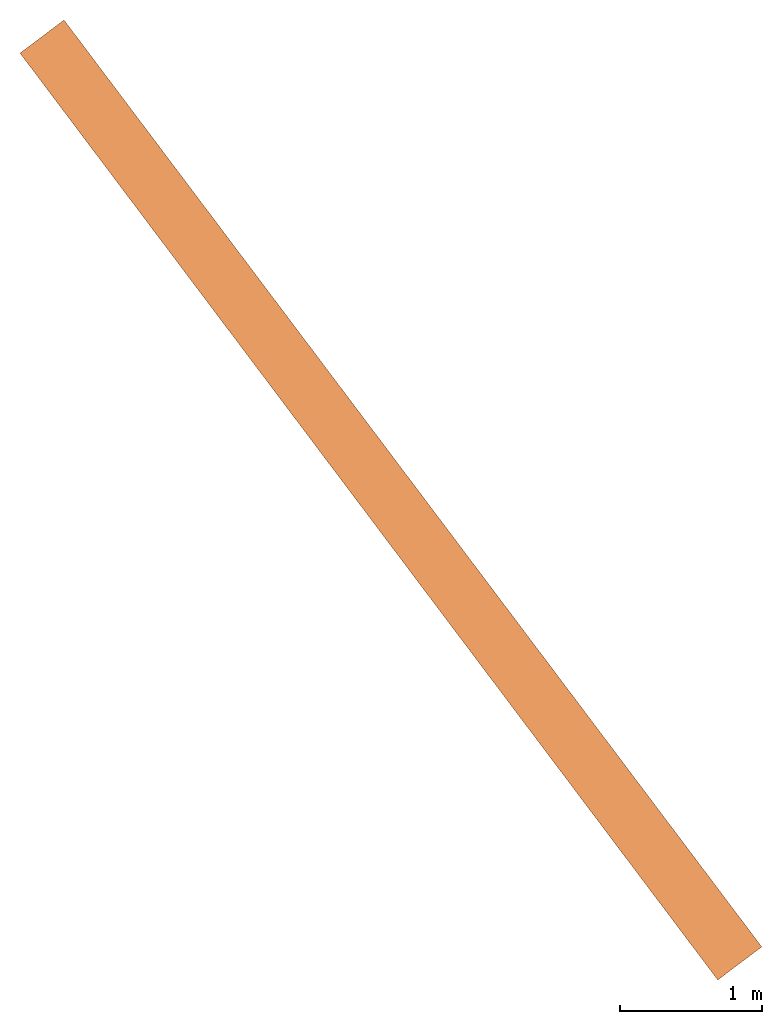
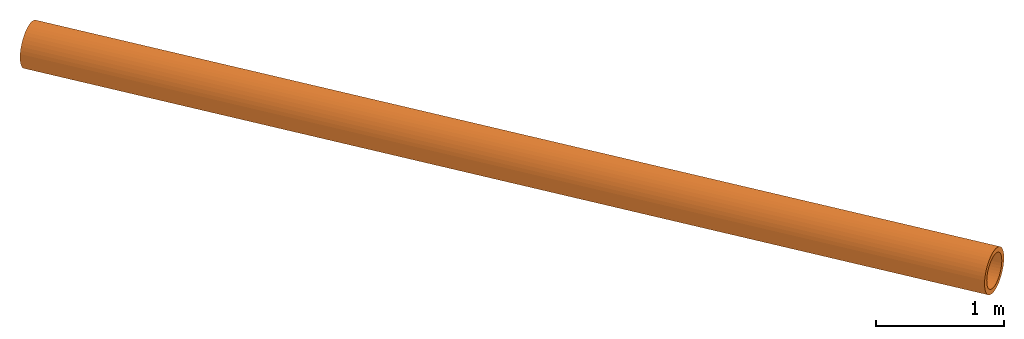
"""IFC2X3 building model written with IfcOpenShell, lengths in metres."""

import ifcopenshell
import ifcopenshell.guid

model = None  # the IFC model being written
_history = None  # IfcOwnerHistory: only IFC2X3 demands one
_inside = {}  # id of a spatial element -> (the spatial element, [elements in it])
_under = {}  # id of a project, library or spatial element -> (it, [spatial elements below it])
_declared = {}  # id of a project -> (the project, [libraries it declares])
_typed = {}  # id of a type object -> (the type object, [elements of that type])
_made_of = {}  # id of a material, layer set ... -> (it, [elements and type objects made of it])


def new_model(schema):
    """Start an empty IFC model of exactly this schema.

    Asked for "IFC4X3", IfcOpenShell would pick the latest addendum, in which some entities
    have other attributes; the version numbers below select the first issue.
    IFC2X3 requires an IfcOwnerHistory on every rooted entity: one is made here for all.
    """
    global model, _history
    if schema == "IFC4X3":
        model = ifcopenshell.file(schema_version=(4, 3, 0, 0))
    else:
        model = ifcopenshell.file(schema=schema)
    _inside.clear()
    _under.clear()
    _declared.clear()
    _typed.clear()
    _made_of.clear()
    _history = None
    if model.schema == "IFC2X3":
        org = make("IfcOrganization", Name="unknown")
        user = make(
            "IfcPersonAndOrganization",
            ThePerson=make("IfcPerson", FamilyName="unknown"),
            TheOrganization=org,
        )
        app = make(
            "IfcApplication",
            ApplicationDeveloper=org,
            Version="unknown",
            ApplicationFullName="unknown",
            ApplicationIdentifier="unknown",
        )
        _history = make(
            "IfcOwnerHistory",
            OwningUser=user,
            OwningApplication=app,
            ChangeAction="ADDED",
            CreationDate=0,
        )
    return model


def make(cls, **values):
    """One entity of the class cls with the attributes given. An attribute that is None is left unset."""
    return model.create_entity(
        cls, **{name: value for name, value in values.items() if value is not None}
    )


def entity(cls, *values):
    """Any entity or typed value of the class cls, its attributes in the order of the schema. None: left unset."""
    e = model.create_entity(cls)
    for i, value in enumerate(values):
        if value is not None:
            e[i] = value
    return e


def rooted(cls, **values):
    """An entity with a GlobalId (a new one), such as an element, a storey or a relation."""
    return make(cls, GlobalId=ifcopenshell.guid.new(), OwnerHistory=_history, **values)


def si_unit(unit_type, name, prefix=None):
    """IfcSIUnit, for example si_unit("LENGTHUNIT", "METRE", prefix="MILLI")."""
    return make("IfcSIUnit", UnitType=unit_type, Prefix=prefix, Name=name)


def converted_unit(unit_type, name, factor, base, dimensions=None, offset=None):
    """IfcConversionBasedUnit, such as the inch: factor (a typed value) times the base unit."""
    return make(
        "IfcConversionBasedUnit"
        if offset is None
        else "IfcConversionBasedUnitWithOffset",
        ConversionOffset=offset,
        Dimensions=None
        if dimensions is None
        else entity("IfcDimensionalExponents", *dimensions),
        UnitType=unit_type,
        Name=name,
        ConversionFactor=make(
            "IfcMeasureWithUnit", ValueComponent=factor, UnitComponent=base
        ),
    )


def assignment(units):
    """IfcUnitAssignment: the units of a project."""
    return None if units is None else make("IfcUnitAssignment", Units=units)


def point(xyz):
    """IfcCartesianPoint."""
    return None if xyz is None else make("IfcCartesianPoint", Coordinates=xyz)


def direction(xyz):
    """IfcDirection."""
    return None if xyz is None else make("IfcDirection", DirectionRatios=xyz)


def frame(location, z_axis=None, x_axis=None):
    """IfcAxis2Placement3D, a coordinate frame: its origin and axes. An axis left out is left unset."""
    return make(
        "IfcAxis2Placement3D",
        Location=point(location),
        Axis=direction(z_axis),
        RefDirection=direction(x_axis),
    )


def origin_with_axes():
    """The frame at (0, 0, 0) with the z axis (0, 0, 1) and the x axis (1, 0, 0) written out."""
    return frame((0.0, 0.0, 0.0), z_axis=(0.0, 0.0, 1.0), x_axis=(1.0, 0.0, 0.0))


def place(relative_to, where):
    """IfcLocalPlacement: puts the frame where relative to a parent placement (None: the world)."""
    return make(
        "IfcLocalPlacement", PlacementRelTo=relative_to, RelativePlacement=where
    )


def context(
    kind, dimensions, precision=None, world=None, true_north=None, identifier=None
):
    """IfcGeometricRepresentationContext, for example the 3D "Model" context."""
    return make(
        "IfcGeometricRepresentationContext",
        ContextIdentifier=identifier,
        ContextType=kind,
        CoordinateSpaceDimension=dimensions,
        Precision=precision,
        WorldCoordinateSystem=world,
        TrueNorth=true_north,
    )


def project(units=None, contexts=None):
    """IfcProject with its units and contexts."""
    return rooted(
        "IfcProject",
        Name="project",
        RepresentationContexts=contexts,
        UnitsInContext=assignment(units),
    )


def spatial(cls, under=None, at=None, **own):
    """A site, building, storey or space (cls), placed at a placement, below another one or the project."""
    s = rooted(cls, ObjectPlacement=at, **own)
    if under is not None:
        _under.setdefault(under.id(), (under, []))[1].append(s)
    return s


def faces_of(points, faces, orient=None, outer=None):
    """IfcFace entities. A face is a list of loops; a loop is a list of indices into points, from 0.

    orient and outer hold one flag for each loop. By default every Orientation is true, the
    first loop of a face is its IfcFaceOuterBound and the others are IfcFaceBound.
    """
    made = []
    for i, loops in enumerate(faces):
        bounds = []
        for j, loop in enumerate(loops):
            is_outer = j == 0 if outer is None else outer[i][j]
            bounds.append(
                make(
                    "IfcFaceOuterBound" if is_outer else "IfcFaceBound",
                    Bound=make("IfcPolyLoop", Polygon=[points[k] for k in loop]),
                    Orientation=True if orient is None else orient[i][j],
                )
            )
        made.append(make("IfcFace", Bounds=bounds))
    return made


def faceted_brep(points, faces, orient=None, outer=None, voids=None):
    """IfcFacetedBrep: a solid bounded by flat faces; with voids (closed shells), ...WithVoids."""
    shared = [point(p) for p in points]
    hull = make("IfcClosedShell", CfsFaces=faces_of(shared, faces, orient, outer))
    if voids is None:
        return make("IfcFacetedBrep", Outer=hull)
    return make(
        "IfcFacetedBrepWithVoids",
        Outer=hull,
        Voids=[
            make(cls, CfsFaces=faces_of(shared, fs, o, b)) for cls, fs, o, b in voids
        ],
    )


def shape(context_of_items, identifier, shape_type, items):
    """IfcShapeRepresentation: the items that make up one representation, for example the "Body"."""
    return make(
        "IfcShapeRepresentation",
        ContextOfItems=context_of_items,
        RepresentationIdentifier=identifier,
        RepresentationType=shape_type,
        Items=items,
    )


def made_of(thing, what):
    """Note that an element or type object is made of a material, layer set ...; save() writes the relation."""
    if what is not None:
        _made_of.setdefault(what.id(), (what, []))[1].append(thing)
    return thing


def element(
    cls,
    number,
    at=None,
    inside=None,
    cuts=None,
    type_object=None,
    material=None,
    context=None,
    identifier="Body",
    shape_type=None,
    held_by="IfcProductDefinitionShape",
    body=None,
    shapes=None,
    **own,
):
    """One element of the class cls, such as IfcWall. Its Tag is "e" and its number.

    at: its placement. inside: the storey or other place that contains it. cuts: it is an
    opening in that element (IfcRelVoidsElement). A single representation is given by context,
    identifier, shape_type and body (its items); several are given by shapes. held_by: the class
    of the entity that holds the representations. save() writes the other relations.
    """
    e = rooted(cls, Tag="e%d" % number, ObjectPlacement=at, **own)
    if body is not None:
        shapes = [shape(context, identifier, shape_type, body)]
    if shapes is not None:
        e.Representation = make(held_by, Representations=shapes)
    if inside is not None:
        _inside.setdefault(inside.id(), (inside, []))[1].append(e)
    if cuts is not None:
        rooted(
            "IfcRelVoidsElement", RelatingBuildingElement=cuts, RelatedOpeningElement=e
        )
    if type_object is not None:
        _typed.setdefault(type_object.id(), (type_object, []))[1].append(e)
    return made_of(e, material)


def aggregate(whole, parts):
    """IfcRelAggregates: a whole, such as a stair, and the parts it consists of."""
    return rooted("IfcRelAggregates", RelatingObject=whole, RelatedObjects=parts)


def save(model, path):
    """Write the relations noted so far, then the file.

    IfcRelAggregates (storeys below a building ...), IfcRelContainedInSpatialStructure (elements
    in a storey), IfcRelDefinesByType, IfcRelAssociatesMaterial and IfcRelDeclares: one each for
    every whole, place, type object, material and project.
    """
    for whole, parts in _under.values():
        aggregate(whole, parts)
    for where, things in _inside.values():
        rooted(
            "IfcRelContainedInSpatialStructure",
            RelatedElements=things,
            RelatingStructure=where,
        )
    for kind, things in _typed.values():
        rooted("IfcRelDefinesByType", RelatedObjects=things, RelatingType=kind)
    for what, things in _made_of.values():
        rooted("IfcRelAssociatesMaterial", RelatedObjects=things, RelatingMaterial=what)
    for by, libraries in _declared.values():
        rooted("IfcRelDeclares", RelatingContext=by, RelatedDefinitions=libraries)
    model.write(path)


model = new_model("IFC2X3")

# Units and contexts
model_context = context("Model", 3, precision=1e-05, world=origin_with_axes(), true_north=direction((0.0, 1.0)))
ifc_project = project(units=[si_unit("LENGTHUNIT", "METRE"), converted_unit("PLANEANGLEUNIT", "Degree", entity("IfcPlaneAngleMeasure", 0.015707963), si_unit("PLANEANGLEUNIT", "RADIAN"), dimensions=[0, 0, 0, 0, 0, 0, 0]), si_unit("AREAUNIT", "SQUARE_METRE"), si_unit("VOLUMEUNIT", "CUBIC_METRE"), si_unit("MASSUNIT", "GRAM", prefix="KILO")], contexts=[model_context])

# Site, building, storeys
site_placement = place(None, frame((0.0, 0.0, 0.0), z_axis=(0.0, 0.0, 1.0), x_axis=(1.0, 6.12323399573677e-17, 0.0)))
site = spatial("IfcSite", under=ifc_project, at=site_placement, CompositionType="ELEMENT")
building_placement = place(None, frame((0.0, 0.0, 0.0), z_axis=(0.0, 0.0, 1.0), x_axis=(1.0, 6.12323399573677e-17, 0.0)))
building = spatial("IfcBuilding", under=site, at=building_placement, Name="(G0) Grupo 0", CompositionType="ELEMENT")
storey_1_placement = place(building_placement, origin_with_axes())
storey_1 = spatial("IfcBuildingStorey", under=building, at=storey_1_placement, Name="(E2)", CompositionType="ELEMENT")
storey_2_placement = place(storey_1_placement, origin_with_axes())
storey_2 = spatial("IfcBuildingStorey", under=storey_1, at=storey_2_placement, CompositionType="PARTIAL")

# Proxy
proxy_placement = place(storey_2_placement, frame((9.057202, -3.186392, 174.6203), z_axis=(0.0, 0.0, 1.0), x_axis=(1.0, 0.0, 0.0)))
element("IfcBuildingElementProxy", 1, at=proxy_placement, inside=storey_2, Name="TUBO 1", ObjectType="TUBO", CompositionType="ELEMENT", context=model_context, shape_type="Brep", body=[
    faceted_brep([(5.068858, 0.116682, 0.4697), (5.068258, 0.117482, 0.4697), (5.092465, 0.135706, 0.4673), (5.093065, 0.134906, 0.4673), (5.116113, 0.153509, 0.4602), (5.116713, 0.152709, 0.4602), (5.138642, 0.17047, 0.4486), (5.139242, 0.16967, 0.4486), (5.159334, 0.186048, 0.4326), (5.159934, 0.185248, 0.4327), (5.177868, 0.200001, 0.4129), (5.178468, 0.199201, 0.4129), (5.193607, 0.21185, 0.3897), (5.194207, 0.21105, 0.3897), (5.206389, 0.221473, 0.3638), (5.206989, 0.220673, 0.3638), (5.215657, 0.22845, 0.3356), (5.216257, 0.22765, 0.3357), (5.221329, 0.23272, 0.306), (5.221929, 0.23192, 0.3061), (5.223246, 0.234164, 0.2757), (5.223846, 0.233364, 0.2757), (4.91387, 0.0, 0.2757), (4.91327, 0.0008, 0.2757), (4.915187, 0.002243, 0.306), (4.915787, 0.001443, 0.3061), (4.92086, 0.006514, 0.3356), (4.92146, 0.005714, 0.3357), (4.930127, 0.013491, 0.3638), (4.930727, 0.012691, 0.3638), (4.942909, 0.023114, 0.3897), (4.943509, 0.022314, 0.3897), (4.958648, 0.034963, 0.4129), (4.959248, 0.034163, 0.4129), (4.977183, 0.048916, 0.4326), (4.977783, 0.048116, 0.4327), (4.997874, 0.064494, 0.4486), (4.998474, 0.063694, 0.4486), (5.020404, 0.081455, 0.4602), (5.021004, 0.080655, 0.4602), (5.044051, 0.099258, 0.4673), (5.044651, 0.098458, 0.4673), (5.221329, 0.23272, 0.2453), (5.221929, 0.23192, 0.2454), (5.215657, 0.22845, 0.2157), (5.216257, 0.22765, 0.2158), (5.206389, 0.221473, 0.1876), (5.206989, 0.220673, 0.1876), (5.193607, 0.21185, 0.1617), (5.194207, 0.21105, 0.1617), (5.177868, 0.200001, 0.1385), (5.178468, 0.199201, 0.1385), (5.159334, 0.186048, 0.1187), (5.159934, 0.185248, 0.1188), (5.138642, 0.17047, 0.1028), (5.139242, 0.16967, 0.1028), (5.116113, 0.153509, 0.0912), (5.116713, 0.152709, 0.0912), (5.092465, 0.135706, 0.0841), (5.093065, 0.134906, 0.0841), (5.068258, 0.117482, 0.0817), (5.068858, 0.116682, 0.0817), (5.044051, 0.099258, 0.0841), (5.044651, 0.098458, 0.0841), (5.020404, 0.081455, 0.0912), (5.021004, 0.080655, 0.0912), (4.997874, 0.064494, 0.1028), (4.998474, 0.063694, 0.1028), (4.977183, 0.048916, 0.1187), (4.977783, 0.048116, 0.1188), (4.958648, 0.034963, 0.1385), (4.959248, 0.034163, 0.1385), (4.942909, 0.023114, 0.1617), (4.943509, 0.022314, 0.1617), (4.930127, 0.013491, 0.1876), (4.930727, 0.012691, 0.1876), (4.92086, 0.006514, 0.2157), (4.92146, 0.005714, 0.2158), (4.915187, 0.002243, 0.2453), (4.915787, 0.001443, 0.2454), (5.087032, 0.131616, 0.4239), (5.068258, 0.117482, 0.4257), (5.068858, 0.116682, 0.4257), (5.087632, 0.130816, 0.4239), (5.105327, 0.145389, 0.4184), (5.105927, 0.144589, 0.4184), (5.122664, 0.158441, 0.4093), (5.123264, 0.157641, 0.4094), (5.138722, 0.17053, 0.397), (5.139322, 0.16973, 0.3971), (5.153022, 0.181296, 0.3818), (5.153622, 0.180496, 0.3818), (5.165246, 0.190498, 0.3639), (5.165846, 0.189698, 0.3639), (5.175072, 0.197896, 0.3438), (5.175672, 0.197096, 0.3438), (5.182262, 0.203309, 0.3221), (5.182862, 0.202509, 0.3221), (5.186656, 0.206617, 0.2992), (5.187256, 0.205817, 0.2992), (5.188094, 0.2077, 0.2757), (5.188694, 0.2069, 0.2757), (4.94986, 0.028347, 0.2992), (4.948422, 0.027264, 0.2757), (4.949022, 0.026464, 0.2757), (4.95046, 0.027547, 0.2992), (4.954254, 0.031655, 0.3221), (4.954854, 0.030855, 0.3221), (4.961444, 0.037068, 0.3438), (4.962044, 0.036268, 0.3438), (4.971271, 0.044466, 0.3639), (4.971871, 0.043666, 0.3639), (4.983494, 0.053668, 0.3818), (4.984094, 0.052868, 0.3818), (4.997794, 0.064434, 0.397), (4.998394, 0.063634, 0.3971), (5.013853, 0.076523, 0.4093), (5.014453, 0.075723, 0.4094), (5.031189, 0.089575, 0.4184), (5.031789, 0.088775, 0.4184), (5.049484, 0.103348, 0.4239), (5.050084, 0.102548, 0.4239), (5.186656, 0.206617, 0.2522), (5.187256, 0.205817, 0.2522), (5.182262, 0.203309, 0.2293), (5.182862, 0.202509, 0.2294), (5.175072, 0.197896, 0.2076), (5.175672, 0.197096, 0.2076), (5.165246, 0.190498, 0.1875), (5.165846, 0.189698, 0.1875), (5.153022, 0.181296, 0.1696), (5.153622, 0.180496, 0.1696), (5.138722, 0.17053, 0.1543), (5.139322, 0.16973, 0.1544), (5.122664, 0.158441, 0.142), (5.123264, 0.157641, 0.1421), (5.105327, 0.145389, 0.133), (5.105927, 0.144589, 0.133), (5.087032, 0.131616, 0.1275), (5.087632, 0.130816, 0.1275), (5.068258, 0.117482, 0.1257), (5.068858, 0.116682, 0.1257), (5.049484, 0.103348, 0.1275), (5.050084, 0.102548, 0.1275), (5.031189, 0.089575, 0.133), (5.031789, 0.088775, 0.133), (5.013853, 0.076523, 0.142), (5.014453, 0.075723, 0.1421), (4.997794, 0.064434, 0.1543), (4.998394, 0.063634, 0.1544), (4.983494, 0.053668, 0.1696), (4.984094, 0.052868, 0.1696), (4.971271, 0.044466, 0.1875), (4.971871, 0.043666, 0.1875), (4.961444, 0.037068, 0.2076), (4.962044, 0.036268, 0.2076), (4.954254, 0.031655, 0.2293), (4.954854, 0.030855, 0.2294), (4.94986, 0.028347, 0.2522), (4.95046, 0.027547, 0.2522), (0.155588, 6.642962, 0.388), (0.179795, 6.661186, 0.3856), (0.203443, 6.678989, 0.3785), (0.225972, 6.69595, 0.3669), (0.246664, 6.711528, 0.351), (0.265198, 6.725481, 0.3312), (0.280937, 6.73733, 0.308), (0.293719, 6.746953, 0.2821), (0.302987, 6.75393, 0.254), (0.308659, 6.7582, 0.2244), (0.310576, 6.759644, 0.194), (0.0006, 6.52628, 0.194), (0.002517, 6.527723, 0.2244), (0.00819, 6.531994, 0.254), (0.017457, 6.538971, 0.2821), (0.030239, 6.548594, 0.308), (0.045978, 6.560443, 0.3312), (0.064513, 6.574396, 0.351), (0.085204, 6.589974, 0.3669), (0.107734, 6.606935, 0.3785), (0.131381, 6.624738, 0.3856), (0.308659, 6.7582, 0.1637), (0.302987, 6.75393, 0.1341), (0.293719, 6.746953, 0.1059), (0.280937, 6.73733, 0.08), (0.265198, 6.725481, 0.0568), (0.246664, 6.711528, 0.0371), (0.225972, 6.69595, 0.0211), (0.203443, 6.678989, 0.0095), (0.179795, 6.661186, 0.0024), (0.155588, 6.642962, 0.0), (0.131381, 6.624738, 0.0024), (0.107734, 6.606935, 0.0095), (0.085204, 6.589974, 0.0211), (0.064513, 6.574396, 0.0371), (0.045978, 6.560443, 0.0568), (0.030239, 6.548594, 0.08), (0.017457, 6.538971, 0.1059), (0.00819, 6.531994, 0.1341), (0.002517, 6.527723, 0.1637), (0.174362, 6.657096, 0.3422), (0.155588, 6.642962, 0.344), (0.192657, 6.670869, 0.3367), (0.209994, 6.683921, 0.3277), (0.226052, 6.69601, 0.3154), (0.240352, 6.706776, 0.3001), (0.252576, 6.715978, 0.2822), (0.262402, 6.723376, 0.2621), (0.269592, 6.728789, 0.2404), (0.273986, 6.732097, 0.2175), (0.275424, 6.73318, 0.194), (0.03719, 6.553827, 0.2175), (0.035752, 6.552744, 0.194), (0.041584, 6.557135, 0.2404), (0.048774, 6.562548, 0.2621), (0.058601, 6.569946, 0.2822), (0.070824, 6.579148, 0.3001), (0.085124, 6.589914, 0.3154), (0.101183, 6.602003, 0.3277), (0.118519, 6.615055, 0.3367), (0.136814, 6.628828, 0.3422), (0.273986, 6.732097, 0.1705), (0.269592, 6.728789, 0.1477), (0.262402, 6.723376, 0.1259), (0.252576, 6.715978, 0.1059), (0.240352, 6.706776, 0.088), (0.226052, 6.69601, 0.0727), (0.209994, 6.683921, 0.0604), (0.192657, 6.670869, 0.0513), (0.174362, 6.657096, 0.0459), (0.155588, 6.642962, 0.044), (0.136814, 6.628828, 0.0459), (0.118519, 6.615055, 0.0513), (0.101183, 6.602003, 0.0604), (0.085124, 6.589914, 0.0727), (0.070824, 6.579148, 0.088), (0.058601, 6.569946, 0.1059), (0.048774, 6.562548, 0.1259), (0.041584, 6.557135, 0.1477), (0.03719, 6.553827, 0.1705), (0.154988, 6.643762, 0.388), (0.179195, 6.661986, 0.3856), (0.202843, 6.679789, 0.3785), (0.225372, 6.69675, 0.3669), (0.246064, 6.712328, 0.351), (0.264598, 6.726281, 0.3312), (0.280337, 6.73813, 0.308), (0.293119, 6.747753, 0.2821), (0.302387, 6.75473, 0.254), (0.308059, 6.759, 0.2244), (0.309976, 6.760444, 0.194), (0.0, 6.52708, 0.194), (0.001917, 6.528523, 0.2244), (0.00759, 6.532794, 0.254), (0.016857, 6.539771, 0.2821), (0.029639, 6.549394, 0.308), (0.045378, 6.561243, 0.3312), (0.063913, 6.575196, 0.351), (0.084604, 6.590774, 0.3669), (0.107134, 6.607735, 0.3785), (0.130781, 6.625538, 0.3856), (0.308059, 6.759, 0.1637), (0.302387, 6.75473, 0.134), (0.293119, 6.747753, 0.1059), (0.280337, 6.73813, 0.08), (0.264598, 6.726281, 0.0568), (0.246064, 6.712328, 0.037), (0.225372, 6.69675, 0.0211), (0.202843, 6.679789, 0.0095), (0.179195, 6.661986, 0.0024), (0.154988, 6.643762, 0.0), (0.130781, 6.625538, 0.0024), (0.107134, 6.607735, 0.0095), (0.084604, 6.590774, 0.0211), (0.063913, 6.575196, 0.037), (0.045378, 6.561243, 0.0568), (0.029639, 6.549394, 0.08), (0.016857, 6.539771, 0.1059), (0.00759, 6.532794, 0.134), (0.001917, 6.528523, 0.1637), (0.173762, 6.657896, 0.3422), (0.154988, 6.643762, 0.344), (0.192057, 6.671669, 0.3367), (0.209394, 6.684721, 0.3277), (0.225452, 6.69681, 0.3154), (0.239752, 6.707576, 0.3001), (0.251976, 6.716778, 0.2822), (0.261802, 6.724176, 0.2621), (0.268992, 6.729589, 0.2404), (0.273386, 6.732897, 0.2175), (0.274824, 6.73398, 0.194), (0.03659, 6.554627, 0.2175), (0.035152, 6.553544, 0.194), (0.040984, 6.557935, 0.2404), (0.048174, 6.563348, 0.2621), (0.058001, 6.570746, 0.2822), (0.070224, 6.579948, 0.3001), (0.084524, 6.590714, 0.3154), (0.100583, 6.602803, 0.3277), (0.117919, 6.615855, 0.3367), (0.136214, 6.629628, 0.3422), (0.273386, 6.732897, 0.1705), (0.268992, 6.729589, 0.1476), (0.261802, 6.724176, 0.1259), (0.251976, 6.716778, 0.1058), (0.239752, 6.707576, 0.0879), (0.225452, 6.69681, 0.0726), (0.209394, 6.684721, 0.0603), (0.192057, 6.671669, 0.0513), (0.173762, 6.657896, 0.0458), (0.154988, 6.643762, 0.044), (0.136214, 6.629628, 0.0458), (0.117919, 6.615855, 0.0513), (0.100583, 6.602803, 0.0603), (0.084524, 6.590714, 0.0726), (0.070224, 6.579948, 0.0879), (0.058001, 6.570746, 0.1058), (0.048174, 6.563348, 0.1259), (0.040984, 6.557935, 0.1476), (0.03659, 6.554627, 0.1705)], [[[0, 1, 2, 3]], [[3, 2, 4, 5]], [[5, 4, 6, 7]], [[7, 6, 8, 9]], [[9, 8, 10, 11]], [[11, 10, 12, 13]], [[13, 12, 14, 15]], [[15, 14, 16, 17]], [[17, 16, 18, 19]], [[19, 18, 20, 21]], [[22, 23, 24, 25]], [[25, 24, 26, 27]], [[27, 26, 28, 29]], [[29, 28, 30, 31]], [[31, 30, 32, 33]], [[33, 32, 34, 35]], [[35, 34, 36, 37]], [[37, 36, 38, 39]], [[39, 38, 40, 41]], [[41, 40, 1, 0]], [[21, 20, 42, 43]], [[43, 42, 44, 45]], [[45, 44, 46, 47]], [[47, 46, 48, 49]], [[49, 48, 50, 51]], [[51, 50, 52, 53]], [[53, 52, 54, 55]], [[55, 54, 56, 57]], [[57, 56, 58, 59]], [[59, 58, 60, 61]], [[61, 60, 62, 63]], [[63, 62, 64, 65]], [[65, 64, 66, 67]], [[67, 66, 68, 69]], [[69, 68, 70, 71]], [[71, 70, 72, 73]], [[73, 72, 74, 75]], [[75, 74, 76, 77]], [[77, 76, 78, 79]], [[79, 78, 23, 22]], [[80, 81, 82, 83]], [[84, 80, 83, 85]], [[86, 84, 85, 87]], [[88, 86, 87, 89]], [[90, 88, 89, 91]], [[92, 90, 91, 93]], [[94, 92, 93, 95]], [[96, 94, 95, 97]], [[98, 96, 97, 99]], [[100, 98, 99, 101]], [[102, 103, 104, 105]], [[106, 102, 105, 107]], [[108, 106, 107, 109]], [[110, 108, 109, 111]], [[112, 110, 111, 113]], [[114, 112, 113, 115]], [[116, 114, 115, 117]], [[118, 116, 117, 119]], [[120, 118, 119, 121]], [[81, 120, 121, 82]], [[122, 100, 101, 123]], [[124, 122, 123, 125]], [[126, 124, 125, 127]], [[128, 126, 127, 129]], [[130, 128, 129, 131]], [[132, 130, 131, 133]], [[134, 132, 133, 135]], [[136, 134, 135, 137]], [[138, 136, 137, 139]], [[140, 138, 139, 141]], [[142, 140, 141, 143]], [[144, 142, 143, 145]], [[146, 144, 145, 147]], [[148, 146, 147, 149]], [[150, 148, 149, 151]], [[152, 150, 151, 153]], [[154, 152, 153, 155]], [[156, 154, 155, 157]], [[158, 156, 157, 159]], [[103, 158, 159, 104]], [[1, 160, 161, 2]], [[2, 161, 162, 4]], [[4, 162, 163, 6]], [[6, 163, 164, 8]], [[8, 164, 165, 10]], [[10, 165, 166, 12]], [[12, 166, 167, 14]], [[14, 167, 168, 16]], [[16, 168, 169, 18]], [[18, 169, 170, 20]], [[23, 171, 172, 24]], [[24, 172, 173, 26]], [[26, 173, 174, 28]], [[28, 174, 175, 30]], [[30, 175, 176, 32]], [[32, 176, 177, 34]], [[34, 177, 178, 36]], [[36, 178, 179, 38]], [[38, 179, 180, 40]], [[40, 180, 160, 1]], [[20, 170, 181, 42]], [[42, 181, 182, 44]], [[44, 182, 183, 46]], [[46, 183, 184, 48]], [[48, 184, 185, 50]], [[50, 185, 186, 52]], [[52, 186, 187, 54]], [[54, 187, 188, 56]], [[56, 188, 189, 58]], [[58, 189, 190, 60]], [[60, 190, 191, 62]], [[62, 191, 192, 64]], [[64, 192, 193, 66]], [[66, 193, 194, 68]], [[68, 194, 195, 70]], [[70, 195, 196, 72]], [[72, 196, 197, 74]], [[74, 197, 198, 76]], [[76, 198, 199, 78]], [[78, 199, 171, 23]], [[200, 201, 81, 80]], [[202, 200, 80, 84]], [[203, 202, 84, 86]], [[204, 203, 86, 88]], [[205, 204, 88, 90]], [[206, 205, 90, 92]], [[207, 206, 92, 94]], [[208, 207, 94, 96]], [[209, 208, 96, 98]], [[210, 209, 98, 100]], [[211, 212, 103, 102]], [[213, 211, 102, 106]], [[214, 213, 106, 108]], [[215, 214, 108, 110]], [[216, 215, 110, 112]], [[217, 216, 112, 114]], [[218, 217, 114, 116]], [[219, 218, 116, 118]], [[220, 219, 118, 120]], [[201, 220, 120, 81]], [[221, 210, 100, 122]], [[222, 221, 122, 124]], [[223, 222, 124, 126]], [[224, 223, 126, 128]], [[225, 224, 128, 130]], [[226, 225, 130, 132]], [[227, 226, 132, 134]], [[228, 227, 134, 136]], [[229, 228, 136, 138]], [[230, 229, 138, 140]], [[231, 230, 140, 142]], [[232, 231, 142, 144]], [[233, 232, 144, 146]], [[234, 233, 146, 148]], [[235, 234, 148, 150]], [[236, 235, 150, 152]], [[237, 236, 152, 154]], [[238, 237, 154, 156]], [[239, 238, 156, 158]], [[212, 239, 158, 103]], [[160, 240, 241, 161]], [[161, 241, 242, 162]], [[162, 242, 243, 163]], [[163, 243, 244, 164]], [[164, 244, 245, 165]], [[165, 245, 246, 166]], [[166, 246, 247, 167]], [[167, 247, 248, 168]], [[168, 248, 249, 169]], [[169, 249, 250, 170]], [[171, 251, 252, 172]], [[172, 252, 253, 173]], [[173, 253, 254, 174]], [[174, 254, 255, 175]], [[175, 255, 256, 176]], [[176, 256, 257, 177]], [[177, 257, 258, 178]], [[178, 258, 259, 179]], [[179, 259, 260, 180]], [[180, 260, 240, 160]], [[170, 250, 261, 181]], [[181, 261, 262, 182]], [[182, 262, 263, 183]], [[183, 263, 264, 184]], [[184, 264, 265, 185]], [[185, 265, 266, 186]], [[186, 266, 267, 187]], [[187, 267, 268, 188]], [[188, 268, 269, 189]], [[189, 269, 270, 190]], [[190, 270, 271, 191]], [[191, 271, 272, 192]], [[192, 272, 273, 193]], [[193, 273, 274, 194]], [[194, 274, 275, 195]], [[195, 275, 276, 196]], [[196, 276, 277, 197]], [[197, 277, 278, 198]], [[198, 278, 279, 199]], [[199, 279, 251, 171]], [[280, 281, 201, 200]], [[282, 280, 200, 202]], [[283, 282, 202, 203]], [[284, 283, 203, 204]], [[285, 284, 204, 205]], [[286, 285, 205, 206]], [[287, 286, 206, 207]], [[288, 287, 207, 208]], [[289, 288, 208, 209]], [[290, 289, 209, 210]], [[291, 292, 212, 211]], [[293, 291, 211, 213]], [[294, 293, 213, 214]], [[295, 294, 214, 215]], [[296, 295, 215, 216]], [[297, 296, 216, 217]], [[298, 297, 217, 218]], [[299, 298, 218, 219]], [[300, 299, 219, 220]], [[281, 300, 220, 201]], [[301, 290, 210, 221]], [[302, 301, 221, 222]], [[303, 302, 222, 223]], [[304, 303, 223, 224]], [[305, 304, 224, 225]], [[306, 305, 225, 226]], [[307, 306, 226, 227]], [[308, 307, 227, 228]], [[309, 308, 228, 229]], [[310, 309, 229, 230]], [[311, 310, 230, 231]], [[312, 311, 231, 232]], [[313, 312, 232, 233]], [[314, 313, 233, 234]], [[315, 314, 234, 235]], [[316, 315, 235, 236]], [[317, 316, 236, 237]], [[318, 317, 237, 238]], [[319, 318, 238, 239]], [[292, 319, 239, 212]], [[75, 155, 73]], [[73, 151, 71]], [[71, 151, 69]], [[151, 73, 153]], [[73, 155, 153]], [[77, 79, 159]], [[159, 157, 77]], [[157, 155, 77]], [[75, 77, 155]], [[159, 79, 104]], [[67, 145, 65]], [[61, 63, 141]], [[61, 141, 59]], [[63, 65, 143]], [[143, 141, 63]], [[69, 151, 149]], [[147, 145, 67]], [[145, 143, 65]], [[147, 69, 149]], [[67, 69, 147]], [[22, 25, 105]], [[107, 105, 25]], [[105, 104, 22]], [[79, 22, 104]], [[107, 25, 27]], [[27, 29, 109]], [[31, 33, 113]], [[31, 109, 29]], [[31, 111, 109]], [[107, 27, 109]], [[33, 115, 113]], [[119, 117, 39]], [[117, 115, 35]], [[35, 115, 33]], [[117, 35, 37]], [[121, 39, 41]], [[37, 39, 117]], [[121, 41, 82]], [[39, 121, 119]], [[31, 113, 111]], [[59, 139, 57]], [[139, 59, 141]], [[57, 137, 55]], [[137, 57, 139]], [[55, 135, 53]], [[137, 135, 55]], [[133, 131, 53]], [[129, 49, 131]], [[53, 135, 133]], [[53, 131, 51]], [[49, 129, 127]], [[131, 49, 51]], [[45, 47, 127]], [[127, 47, 49]], [[45, 127, 125]], [[45, 125, 123]], [[43, 101, 21]], [[101, 43, 123]], [[21, 101, 99]], [[43, 45, 123]], [[85, 83, 5]], [[87, 9, 89]], [[87, 7, 9]], [[87, 85, 5]], [[0, 82, 41]], [[82, 0, 3]], [[3, 83, 82]], [[5, 83, 3]], [[7, 87, 5]], [[91, 89, 11]], [[97, 95, 17]], [[17, 19, 97]], [[99, 19, 21]], [[97, 19, 99]], [[17, 95, 15]], [[11, 89, 9]], [[93, 91, 13]], [[11, 13, 91]], [[95, 93, 13]], [[15, 95, 13]], [[276, 317, 277]], [[275, 315, 276]], [[274, 314, 275]], [[316, 276, 315]], [[316, 317, 276]], [[319, 279, 278]], [[278, 318, 319]], [[278, 317, 318]], [[317, 278, 277]], [[292, 279, 319]], [[272, 313, 273]], [[310, 271, 270]], [[269, 310, 270]], [[311, 272, 271]], [[271, 310, 311]], [[314, 315, 275]], [[272, 312, 313]], [[272, 311, 312]], [[314, 274, 313]], [[313, 274, 273]], [[291, 252, 251]], [[252, 291, 293]], [[251, 292, 291]], [[292, 251, 279]], [[253, 252, 293]], [[294, 254, 253]], [[296, 256, 255]], [[254, 294, 255]], [[294, 295, 255]], [[294, 253, 293]], [[296, 297, 256]], [[259, 298, 299]], [[257, 297, 298]], [[256, 297, 257]], [[258, 257, 298]], [[260, 259, 300]], [[298, 259, 258]], [[281, 260, 300]], [[299, 300, 259]], [[295, 296, 255]], [[268, 309, 269]], [[310, 269, 309]], [[267, 307, 268]], [[309, 268, 308]], [[266, 307, 267]], [[268, 307, 308]], [[306, 265, 305]], [[305, 264, 304]], [[306, 307, 266]], [[266, 265, 306]], [[303, 304, 264]], [[265, 264, 305]], [[303, 263, 262]], [[264, 263, 303]], [[302, 303, 262]], [[301, 302, 262]], [[250, 290, 261]], [[301, 261, 290]], [[289, 290, 250]], [[301, 262, 261]], [[242, 280, 282]], [[284, 244, 283]], [[244, 243, 283]], [[242, 282, 283]], [[260, 281, 240]], [[241, 240, 281]], [[281, 280, 241]], [[241, 280, 242]], [[242, 283, 243]], [[245, 284, 285]], [[248, 287, 288]], [[288, 249, 248]], [[250, 249, 289]], [[289, 249, 288]], [[247, 287, 248]], [[244, 284, 245]], [[246, 285, 286]], [[285, 246, 245]], [[246, 286, 287]], [[246, 287, 247]]], orient=[[False], [False], [False], [False], [False], [False], [False], [False], [False], [False], [False], [False], [False], [False], [False], [False], [False], [False], [False], [False], [False], [False], [False], [False], [False], [False], [False], [False], [False], [False], [False], [False], [False], [False], [False], [False], [False], [False], [False], [False], [False], [False], [False], [False], [False], [False], [False], [False], [False], [False], [False], [False], [False], [False], [False], [False], [False], [False], [False], [False], [False], [False], [False], [False], [False], [False], [False], [False], [False], [False], [False], [False], [False], [False], [False], [False], [False], [False], [False], [False], [False], [False], [False], [False], [False], [False], [False], [False], [False], [False], [False], [False], [False], [False], [False], [False], [False], [False], [False], [False], [False], [False], [False], [False], [False], [False], [False], [False], [False], [False], [False], [False], [False], [False], [False], [False], [False], [False], [False], [False], [False], [False], [False], [False], [False], [False], [False], [False], [False], [False], [False], [False], [False], [False], [False], [False], [False], [False], [False], [False], [False], [False], [False], [False], [False], [False], [False], [False], [False], [False], [False], [False], [False], [False], [False], [False], [False], [False], [False], [False], [False], [False], [False], [False], [False], [False], [False], [False], [False], [False], [False], [False], [False], [False], [False], [False], [False], [False], [False], [False], [False], [False], [False], [False], [False], [False], [False], [False], [False], [False], [False], [False], [False], [False], [False], [False], [False], [False], [False], [False], [False], [False], [False], [False], [False], [False], [False], [False], [False], [False], [False], [False], [False], [False], [False], [False], [False], [False], [False], [False], [False], [False], [False], [False], [False], [False], [False], [False], [False], [False], [False], [False], [False], [False], [False], [False], [False], [False], [False], [False], [False], [False], [False], [False], [False], [False], [False], [False], [False], [False], [False], [False], [False], [False], [False], [False], [False], [False], [False], [False], [False], [False], [False], [False], [False], [False], [False], [False], [False], [False], [False], [False], [False], [False], [False], [False], [False], [False], [False], [False], [False], [False], [False], [False], [False], [False], [False], [False], [False], [False], [False], [False], [False], [False], [False], [False], [False], [False], [False], [False], [False], [False], [False], [False], [False], [False], [False], [False], [False], [False], [False], [False], [False], [False], [False], [False], [False], [False], [False], [False], [False], [False], [False], [False], [False], [False], [False], [False], [False], [False], [False], [False], [False], [False], [False], [False], [False], [False], [False], [False], [False], [False], [False], [False], [False], [False], [False], [False], [False], [False], [False], [False], [False], [False], [False], [False], [False], [False], [False], [False], [False], [False], [False], [False], [False], [False], [False], [False], [False], [False], [False], [False], [False], [False], [False], [False], [False], [False], [False], [False], [False], [False], [False], [False], [False], [False], [False], [False], [False], [False], [False], [False], [False], [False], [False], [False], [False], [False], [False], [False]]),
])

save(model, "model.ifc")
